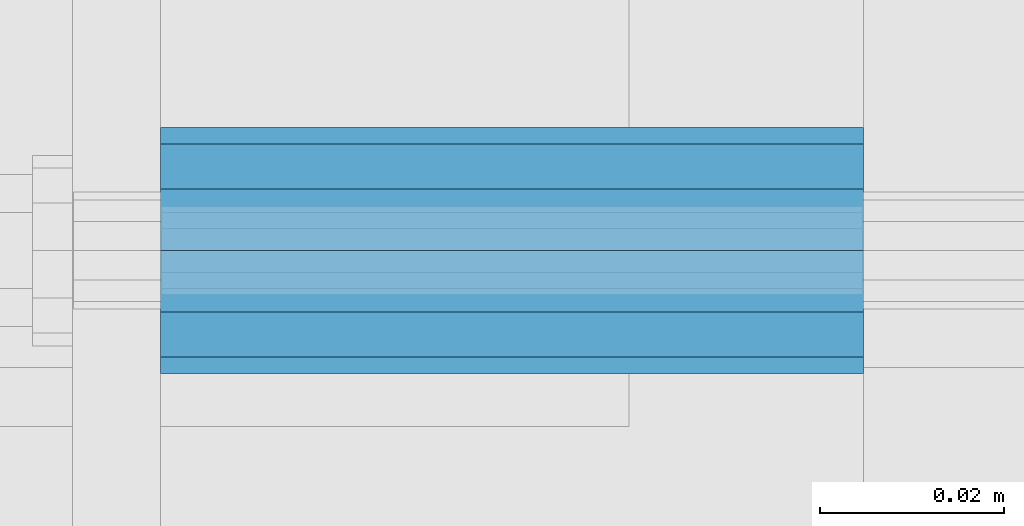
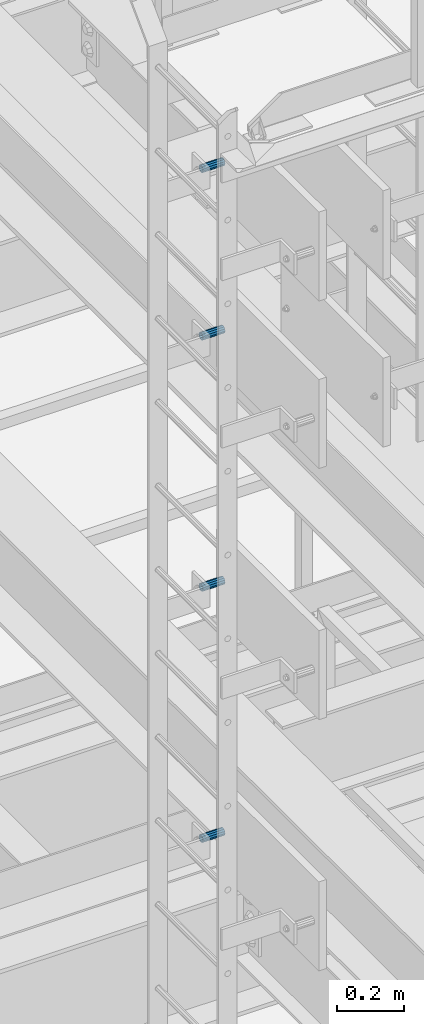
# One storey, part 2809 of 3843: 4 beams, 4 elements without a shape of their own.
"""IFC2X3 building model written with IfcOpenShell, lengths in millimetres."""

from ifc_helpers import new_model, si_unit, frame, origin_with_axes, place, context, subcontext, project, spatial, faceted_brep, material, type_object, element, aggregate, save


model = new_model("IFC2X3")

# Units and contexts
model_context = context("Model", 3, precision=1e-05, world=origin_with_axes())
body_context = subcontext(model_context, "Body", "Model", "MODEL_VIEW")
ifc_project = project(units=[si_unit("LENGTHUNIT", "METRE", prefix="MILLI"), si_unit("AREAUNIT", "SQUARE_METRE"), si_unit("VOLUMEUNIT", "CUBIC_METRE"), si_unit("MASSUNIT", "GRAM", prefix="KILO"), si_unit("TIMEUNIT", "SECOND"), si_unit("PLANEANGLEUNIT", "RADIAN"), si_unit("SOLIDANGLEUNIT", "STERADIAN"), si_unit("THERMODYNAMICTEMPERATUREUNIT", "DEGREE_CELSIUS"), si_unit("LUMINOUSINTENSITYUNIT", "LUMEN")], contexts=[model_context])

# Site, building, storey
site_placement = place(None, origin_with_axes())
site = spatial("IfcSite", under=ifc_project, at=site_placement, CompositionType="ELEMENT")
building_placement = place(site_placement, origin_with_axes())
building = spatial("IfcBuilding", under=site, at=building_placement, Name="Undefined", CompositionType="ELEMENT")
storey_placement = place(building_placement, origin_with_axes())
storey = spatial("IfcBuildingStorey", under=building, at=storey_placement, Name="Undefined", CompositionType="ELEMENT", Elevation=0.0)

# Assembly, beam
assembly_1_placement = place(storey_placement, origin_with_axes())
assembly_1 = element("IfcElementAssembly", 1, at=assembly_1_placement, inside=storey, Name="SLEEVE", AssemblyPlace="NOTDEFINED", PredefinedType="RIGID_FRAME")
ifc_material = material()
beam_type = type_object("IfcBeamType", Name="PIPE3/4SCH40", PredefinedType="NOTDEFINED")
beam_1_placement = place(assembly_1_placement, frame((48390.1749877929, 17919.6999999995, 41192.45), z_axis=(0.0, 0.0, 1.0), x_axis=(1.0, 0.0, 0.0)))
beam_1 = element("IfcBeam", 2, at=beam_1_placement, type_object=beam_type, material=ifc_material, Name="SLEEVE", ObjectType="PIPE3/4SCH40", context=body_context, shape_type="Brep", body=[
    faceted_brep([(0.0, -10.4648000000016, 7.27595761418343e-12), (-7.27595761418343e-12, -9.06278264552384, 5.23240000000806), (76.2000000004009, -9.06278264552384, 5.2324000001172), (76.2000000004045, -10.4648000000016, 1.16415321826935e-10), (-1.45519152283669e-11, -5.23240000000078, 9.06278264553839), (76.20000000039, -5.23240000000078, 9.06278264564753), (-1.45519152283669e-11, 0.0, 10.4648000000161), (76.20000000039, 0.0, 10.4648000001253), (-1.45519152283669e-11, 5.23240000000078, 9.06278264553839), (76.20000000039, 5.23240000000078, 9.06278264564753), (-7.27595761418343e-12, 9.06278264552384, 5.23240000000806), (76.2000000004009, 9.06278264552384, 5.2324000001172), (0.0, 10.4648000000016, 7.27595761418343e-12), (76.2000000004045, 10.4648000000016, 1.16415321826935e-10), (1.09139364212751e-11, 9.06278264552384, -5.2323999999935), (76.2000000004155, 9.06278264552384, -5.23239999988436), (1.45519152283669e-11, 5.23240000000078, -9.06278264551656), (76.2000000004191, 5.23240000000078, -9.06278264540742), (1.45519152283669e-11, 0.0, -10.4647999999943), (76.2000000004191, 0.0, -10.4647999998851), (1.45519152283669e-11, -5.23240000000078, -9.06278264551656), (76.2000000004191, -5.23240000000078, -9.06278264540742), (1.09139364212751e-11, -9.06278264552384, -5.2323999999935), (76.2000000004155, -9.06278264552384, -5.23239999988436), (0.0, -13.3349999999991, 7.27595761418343e-12), (1.09139364212751e-11, -11.5484487594658, -6.66749999999593), (76.2000000004155, -11.5484487594658, -6.66749999988679), (76.2000000004045, -13.3349999999991, 1.16415321826935e-10), (1.45519152283669e-11, -6.66749999999956, -11.5484487594586), (76.2000000004191, -6.66749999999956, -11.5484487593494), (1.81898940354586e-11, 0.0, -13.3349999999919), (76.2000000004227, 0.0, -13.3349999998827), (1.45519152283669e-11, 6.66749999999956, -11.5484487594586), (76.2000000004191, 6.66749999999956, -11.5484487593494), (1.09139364212751e-11, 11.5484487594658, -6.66749999999593), (76.2000000004155, 11.5484487594658, -6.66749999988679), (0.0, 13.3349999999991, 7.27595761418343e-12), (76.2000000004045, 13.3349999999991, 1.16415321826935e-10), (-7.27595761418343e-12, 11.5484487594658, 6.66750000001048), (76.2000000003973, 11.5484487594658, 6.66750000011234), (-1.45519152283669e-11, 6.66749999999956, 11.5484487594804), (76.20000000039, 6.66749999999956, 11.5484487595895), (-1.81898940354586e-11, 0.0, 13.3350000000137), (76.2000000003864, 0.0, 13.3350000001228), (-1.45519152283669e-11, -6.66749999999956, 11.5484487594804), (76.20000000039, -6.66749999999956, 11.5484487595895), (-7.27595761418343e-12, -11.5484487594658, 6.66750000001048), (76.2000000003973, -11.5484487594658, 6.66750000011234)], [[[0, 1, 2, 3]], [[1, 4, 5, 2]], [[4, 6, 7, 5]], [[6, 8, 9, 7]], [[8, 10, 11, 9]], [[10, 12, 13, 11]], [[12, 14, 15, 13]], [[14, 16, 17, 15]], [[16, 18, 19, 17]], [[18, 20, 21, 19]], [[20, 22, 23, 21]], [[22, 0, 3, 23]], [[24, 25, 26, 27]], [[25, 28, 29, 26]], [[28, 30, 31, 29]], [[30, 32, 33, 31]], [[32, 34, 35, 33]], [[34, 36, 37, 35]], [[36, 38, 39, 37]], [[38, 40, 41, 39]], [[40, 42, 43, 41]], [[42, 44, 45, 43]], [[44, 46, 47, 45]], [[46, 24, 27, 47]], [[29, 31, 33, 35, 37, 39, 41, 43, 45, 47, 27, 26], [5, 7, 9, 11, 13, 15, 17, 19, 21, 23, 3, 2]], [[46, 44, 42, 40, 38, 36, 34, 32, 30, 28, 25, 24], [22, 20, 18, 16, 14, 12, 10, 8, 6, 4, 1, 0]]]),
])
aggregate(assembly_1, [beam_1])

assembly_2_placement = place(storey_placement, origin_with_axes())
assembly_2 = element("IfcElementAssembly", 3, at=assembly_2_placement, inside=storey, Name="SLEEVE", AssemblyPlace="NOTDEFINED", PredefinedType="RIGID_FRAME")
beam_2_placement = place(assembly_2_placement, frame((48390.1749877929, 17919.6999999995, 42106.85), z_axis=(0.0, 0.0, 1.0), x_axis=(1.0, 0.0, 0.0)))
beam_2 = element("IfcBeam", 4, at=beam_2_placement, type_object=beam_type, material=ifc_material, Name="SLEEVE", ObjectType="PIPE3/4SCH40", context=body_context, shape_type="Brep", body=[
    faceted_brep([(0.0, -10.4648000000016, 7.27595761418343e-12), (-7.27595761418343e-12, -9.06278264552384, 5.23240000000806), (76.2000000004009, -9.06278264552384, 5.2324000001172), (76.2000000004045, -10.4648000000016, 1.16415321826935e-10), (-1.45519152283669e-11, -5.23240000000078, 9.06278264553839), (76.20000000039, -5.23240000000078, 9.06278264564753), (-1.45519152283669e-11, 0.0, 10.4648000000161), (76.20000000039, 0.0, 10.4648000001253), (-1.45519152283669e-11, 5.23240000000078, 9.06278264553839), (76.20000000039, 5.23240000000078, 9.06278264564753), (-7.27595761418343e-12, 9.06278264552384, 5.23240000000806), (76.2000000004009, 9.06278264552384, 5.2324000001172), (0.0, 10.4648000000016, 7.27595761418343e-12), (76.2000000004045, 10.4648000000016, 1.16415321826935e-10), (1.09139364212751e-11, 9.06278264552384, -5.2323999999935), (76.2000000004155, 9.06278264552384, -5.23239999988436), (1.45519152283669e-11, 5.23240000000078, -9.06278264551656), (76.2000000004191, 5.23240000000078, -9.06278264540742), (1.45519152283669e-11, 0.0, -10.4647999999943), (76.2000000004191, 0.0, -10.4647999998851), (1.45519152283669e-11, -5.23240000000078, -9.06278264551656), (76.2000000004191, -5.23240000000078, -9.06278264540742), (1.09139364212751e-11, -9.06278264552384, -5.2323999999935), (76.2000000004155, -9.06278264552384, -5.23239999988436), (0.0, -13.3349999999991, 7.27595761418343e-12), (1.09139364212751e-11, -11.5484487594658, -6.66749999999593), (76.2000000004155, -11.5484487594658, -6.66749999988679), (76.2000000004045, -13.3349999999991, 1.16415321826935e-10), (1.45519152283669e-11, -6.66749999999956, -11.5484487594586), (76.2000000004191, -6.66749999999956, -11.5484487593494), (1.81898940354586e-11, 0.0, -13.3349999999919), (76.2000000004227, 0.0, -13.3349999998827), (1.45519152283669e-11, 6.66749999999956, -11.5484487594586), (76.2000000004191, 6.66749999999956, -11.5484487593494), (1.09139364212751e-11, 11.5484487594658, -6.66749999999593), (76.2000000004155, 11.5484487594658, -6.66749999988679), (0.0, 13.3349999999991, 7.27595761418343e-12), (76.2000000004045, 13.3349999999991, 1.16415321826935e-10), (-7.27595761418343e-12, 11.5484487594658, 6.66750000001048), (76.2000000003973, 11.5484487594658, 6.66750000011234), (-1.45519152283669e-11, 6.66749999999956, 11.5484487594804), (76.20000000039, 6.66749999999956, 11.5484487595895), (-1.81898940354586e-11, 0.0, 13.3350000000137), (76.2000000003864, 0.0, 13.3350000001228), (-1.45519152283669e-11, -6.66749999999956, 11.5484487594804), (76.20000000039, -6.66749999999956, 11.5484487595895), (-7.27595761418343e-12, -11.5484487594658, 6.66750000001048), (76.2000000003973, -11.5484487594658, 6.66750000011234)], [[[0, 1, 2, 3]], [[1, 4, 5, 2]], [[4, 6, 7, 5]], [[6, 8, 9, 7]], [[8, 10, 11, 9]], [[10, 12, 13, 11]], [[12, 14, 15, 13]], [[14, 16, 17, 15]], [[16, 18, 19, 17]], [[18, 20, 21, 19]], [[20, 22, 23, 21]], [[22, 0, 3, 23]], [[24, 25, 26, 27]], [[25, 28, 29, 26]], [[28, 30, 31, 29]], [[30, 32, 33, 31]], [[32, 34, 35, 33]], [[34, 36, 37, 35]], [[36, 38, 39, 37]], [[38, 40, 41, 39]], [[40, 42, 43, 41]], [[42, 44, 45, 43]], [[44, 46, 47, 45]], [[46, 24, 27, 47]], [[29, 31, 33, 35, 37, 39, 41, 43, 45, 47, 27, 26], [5, 7, 9, 11, 13, 15, 17, 19, 21, 23, 3, 2]], [[46, 44, 42, 40, 38, 36, 34, 32, 30, 28, 25, 24], [22, 20, 18, 16, 14, 12, 10, 8, 6, 4, 1, 0]]]),
])
aggregate(assembly_2, [beam_2])

assembly_3_placement = place(storey_placement, origin_with_axes())
assembly_3 = element("IfcElementAssembly", 5, at=assembly_3_placement, inside=storey, Name="SLEEVE", AssemblyPlace="NOTDEFINED", PredefinedType="RIGID_FRAME")
beam_3_placement = place(assembly_3_placement, frame((48390.1749877929, 17919.6999999995, 43021.25), z_axis=(0.0, 0.0, 1.0), x_axis=(1.0, 0.0, 0.0)))
beam_3 = element("IfcBeam", 6, at=beam_3_placement, type_object=beam_type, material=ifc_material, Name="SLEEVE", ObjectType="PIPE3/4SCH40", context=body_context, shape_type="Brep", body=[
    faceted_brep([(0.0, -10.4648000000016, 7.27595761418343e-12), (-7.27595761418343e-12, -9.06278264552384, 5.23240000000806), (76.2000000004009, -9.06278264552384, 5.2324000001172), (76.2000000004045, -10.4648000000016, 1.16415321826935e-10), (-1.45519152283669e-11, -5.23240000000078, 9.06278264553839), (76.20000000039, -5.23240000000078, 9.06278264564753), (-1.45519152283669e-11, 0.0, 10.4648000000161), (76.20000000039, 0.0, 10.4648000001253), (-1.45519152283669e-11, 5.23240000000078, 9.06278264553839), (76.20000000039, 5.23240000000078, 9.06278264564753), (-7.27595761418343e-12, 9.06278264552384, 5.23240000000806), (76.2000000004009, 9.06278264552384, 5.2324000001172), (0.0, 10.4648000000016, 7.27595761418343e-12), (76.2000000004045, 10.4648000000016, 1.16415321826935e-10), (1.09139364212751e-11, 9.06278264552384, -5.2323999999935), (76.2000000004155, 9.06278264552384, -5.23239999988436), (1.45519152283669e-11, 5.23240000000078, -9.06278264551656), (76.2000000004191, 5.23240000000078, -9.06278264540742), (1.45519152283669e-11, 0.0, -10.4647999999943), (76.2000000004191, 0.0, -10.4647999998851), (1.45519152283669e-11, -5.23240000000078, -9.06278264551656), (76.2000000004191, -5.23240000000078, -9.06278264540742), (1.09139364212751e-11, -9.06278264552384, -5.2323999999935), (76.2000000004155, -9.06278264552384, -5.23239999988436), (0.0, -13.3349999999991, 7.27595761418343e-12), (1.09139364212751e-11, -11.5484487594658, -6.66749999999593), (76.2000000004155, -11.5484487594658, -6.66749999988679), (76.2000000004045, -13.3349999999991, 1.16415321826935e-10), (1.45519152283669e-11, -6.66749999999956, -11.5484487594586), (76.2000000004191, -6.66749999999956, -11.5484487593494), (1.81898940354586e-11, 0.0, -13.3349999999919), (76.2000000004227, 0.0, -13.3349999998827), (1.45519152283669e-11, 6.66749999999956, -11.5484487594586), (76.2000000004191, 6.66749999999956, -11.5484487593494), (1.09139364212751e-11, 11.5484487594658, -6.66749999999593), (76.2000000004155, 11.5484487594658, -6.66749999988679), (0.0, 13.3349999999991, 7.27595761418343e-12), (76.2000000004045, 13.3349999999991, 1.16415321826935e-10), (-7.27595761418343e-12, 11.5484487594658, 6.66750000001048), (76.2000000003973, 11.5484487594658, 6.66750000011234), (-1.45519152283669e-11, 6.66749999999956, 11.5484487594804), (76.20000000039, 6.66749999999956, 11.5484487595895), (-1.81898940354586e-11, 0.0, 13.3350000000137), (76.2000000003864, 0.0, 13.3350000001228), (-1.45519152283669e-11, -6.66749999999956, 11.5484487594804), (76.20000000039, -6.66749999999956, 11.5484487595895), (-7.27595761418343e-12, -11.5484487594658, 6.66750000001048), (76.2000000003973, -11.5484487594658, 6.66750000011234)], [[[0, 1, 2, 3]], [[1, 4, 5, 2]], [[4, 6, 7, 5]], [[6, 8, 9, 7]], [[8, 10, 11, 9]], [[10, 12, 13, 11]], [[12, 14, 15, 13]], [[14, 16, 17, 15]], [[16, 18, 19, 17]], [[18, 20, 21, 19]], [[20, 22, 23, 21]], [[22, 0, 3, 23]], [[24, 25, 26, 27]], [[25, 28, 29, 26]], [[28, 30, 31, 29]], [[30, 32, 33, 31]], [[32, 34, 35, 33]], [[34, 36, 37, 35]], [[36, 38, 39, 37]], [[38, 40, 41, 39]], [[40, 42, 43, 41]], [[42, 44, 45, 43]], [[44, 46, 47, 45]], [[46, 24, 27, 47]], [[29, 31, 33, 35, 37, 39, 41, 43, 45, 47, 27, 26], [5, 7, 9, 11, 13, 15, 17, 19, 21, 23, 3, 2]], [[46, 44, 42, 40, 38, 36, 34, 32, 30, 28, 25, 24], [22, 20, 18, 16, 14, 12, 10, 8, 6, 4, 1, 0]]]),
])
aggregate(assembly_3, [beam_3])

assembly_4_placement = place(storey_placement, origin_with_axes())
assembly_4 = element("IfcElementAssembly", 7, at=assembly_4_placement, inside=storey, Name="SLEEVE", AssemblyPlace="NOTDEFINED", PredefinedType="RIGID_FRAME")
beam_4_placement = place(assembly_4_placement, frame((48390.174987793, 17919.6999999995, 43630.85), z_axis=(0.0, 0.0, 1.0), x_axis=(1.0, 0.0, 0.0)))
beam_4 = element("IfcBeam", 8, at=beam_4_placement, type_object=beam_type, material=ifc_material, Name="SLEEVE", ObjectType="PIPE3/4SCH40", context=body_context, shape_type="Brep", body=[
    faceted_brep([(0.0, -10.4648000000016, 7.27595761418343e-12), (-7.27595761418343e-12, -9.06278264552384, 5.23240000000806), (76.2000000004009, -9.06278264552384, 5.2324000001172), (76.2000000004045, -10.4648000000016, 1.16415321826935e-10), (-1.45519152283669e-11, -5.23240000000078, 9.06278264553839), (76.20000000039, -5.23240000000078, 9.06278264564753), (-1.45519152283669e-11, 0.0, 10.4648000000161), (76.20000000039, 0.0, 10.4648000001253), (-1.45519152283669e-11, 5.23240000000078, 9.06278264553839), (76.20000000039, 5.23240000000078, 9.06278264564753), (-7.27595761418343e-12, 9.06278264552384, 5.23240000000806), (76.2000000004009, 9.06278264552384, 5.2324000001172), (0.0, 10.4648000000016, 7.27595761418343e-12), (76.2000000004045, 10.4648000000016, 1.16415321826935e-10), (1.09139364212751e-11, 9.06278264552384, -5.2323999999935), (76.2000000004155, 9.06278264552384, -5.23239999988436), (1.45519152283669e-11, 5.23240000000078, -9.06278264551656), (76.2000000004191, 5.23240000000078, -9.06278264540742), (1.45519152283669e-11, 0.0, -10.4647999999943), (76.2000000004191, 0.0, -10.4647999998851), (1.45519152283669e-11, -5.23240000000078, -9.06278264551656), (76.2000000004191, -5.23240000000078, -9.06278264540742), (1.09139364212751e-11, -9.06278264552384, -5.2323999999935), (76.2000000004155, -9.06278264552384, -5.23239999988436), (0.0, -13.3349999999991, 7.27595761418343e-12), (1.09139364212751e-11, -11.5484487594658, -6.66749999999593), (76.2000000004155, -11.5484487594658, -6.66749999988679), (76.2000000004045, -13.3349999999991, 1.16415321826935e-10), (1.45519152283669e-11, -6.66749999999956, -11.5484487594586), (76.2000000004191, -6.66749999999956, -11.5484487593494), (1.81898940354586e-11, 0.0, -13.3349999999919), (76.2000000004227, 0.0, -13.3349999998827), (1.45519152283669e-11, 6.66749999999956, -11.5484487594586), (76.2000000004191, 6.66749999999956, -11.5484487593494), (1.09139364212751e-11, 11.5484487594658, -6.66749999999593), (76.2000000004155, 11.5484487594658, -6.66749999988679), (0.0, 13.3349999999991, 7.27595761418343e-12), (76.2000000004045, 13.3349999999991, 1.16415321826935e-10), (-7.27595761418343e-12, 11.5484487594658, 6.66750000001048), (76.2000000003973, 11.5484487594658, 6.66750000011234), (-1.45519152283669e-11, 6.66749999999956, 11.5484487594804), (76.20000000039, 6.66749999999956, 11.5484487595895), (-1.81898940354586e-11, 0.0, 13.3350000000137), (76.2000000003864, 0.0, 13.3350000001228), (-1.45519152283669e-11, -6.66749999999956, 11.5484487594804), (76.20000000039, -6.66749999999956, 11.5484487595895), (-7.27595761418343e-12, -11.5484487594658, 6.66750000001048), (76.2000000003973, -11.5484487594658, 6.66750000011234)], [[[0, 1, 2, 3]], [[1, 4, 5, 2]], [[4, 6, 7, 5]], [[6, 8, 9, 7]], [[8, 10, 11, 9]], [[10, 12, 13, 11]], [[12, 14, 15, 13]], [[14, 16, 17, 15]], [[16, 18, 19, 17]], [[18, 20, 21, 19]], [[20, 22, 23, 21]], [[22, 0, 3, 23]], [[24, 25, 26, 27]], [[25, 28, 29, 26]], [[28, 30, 31, 29]], [[30, 32, 33, 31]], [[32, 34, 35, 33]], [[34, 36, 37, 35]], [[36, 38, 39, 37]], [[38, 40, 41, 39]], [[40, 42, 43, 41]], [[42, 44, 45, 43]], [[44, 46, 47, 45]], [[46, 24, 27, 47]], [[29, 31, 33, 35, 37, 39, 41, 43, 45, 47, 27, 26], [5, 7, 9, 11, 13, 15, 17, 19, 21, 23, 3, 2]], [[46, 44, 42, 40, 38, 36, 34, 32, 30, 28, 25, 24], [22, 20, 18, 16, 14, 12, 10, 8, 6, 4, 1, 0]]]),
])
aggregate(assembly_4, [beam_4])

save(model, "model.ifc")
